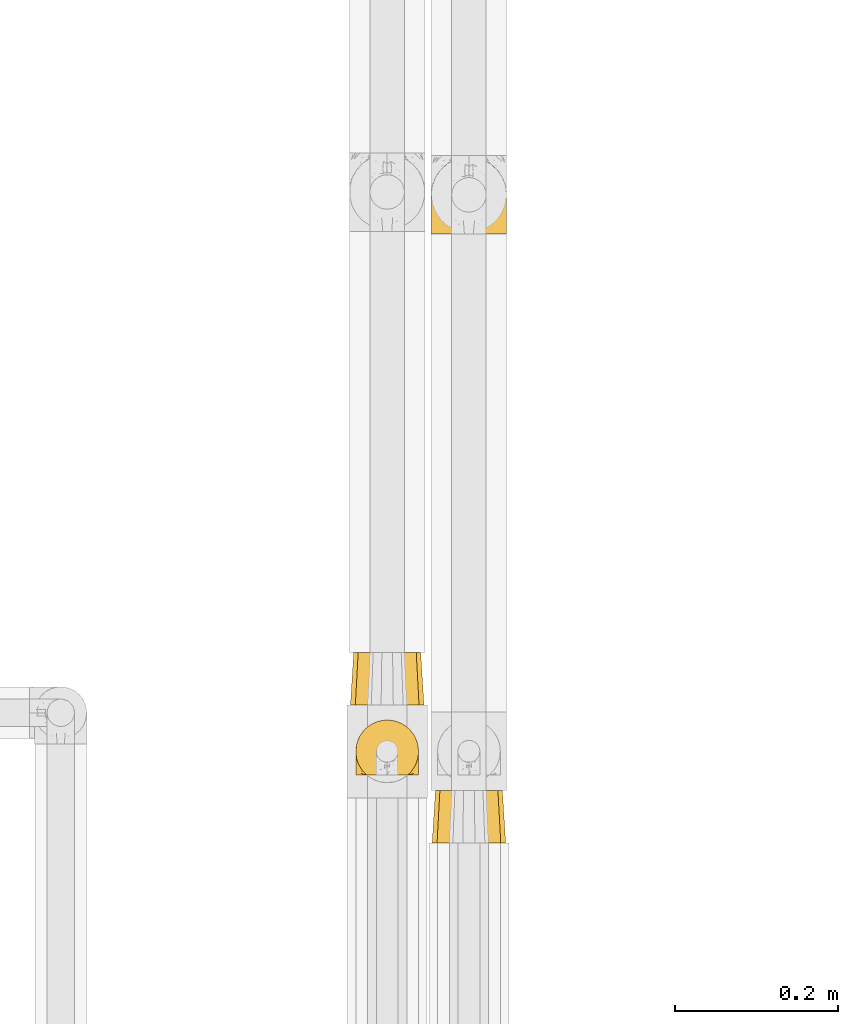
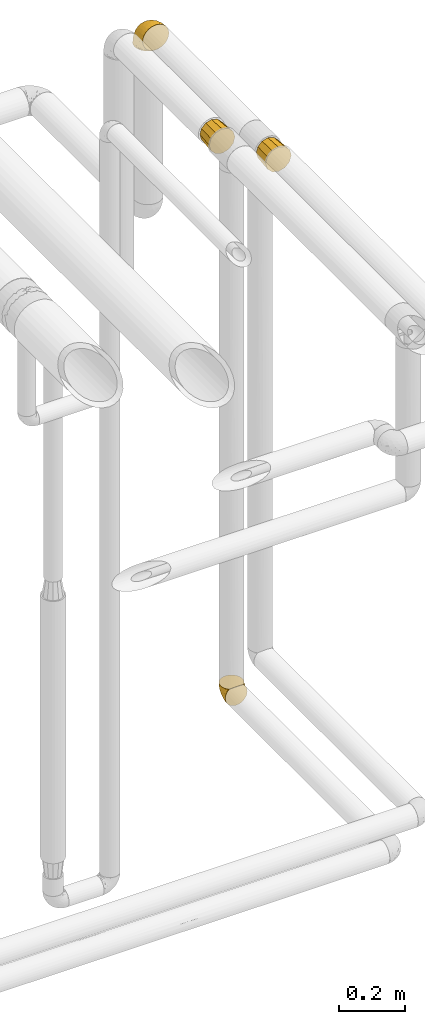
# One storey, part 509 of 827: 4 coverings.
"""IFC2X3 building model written with IfcOpenShell, lengths in millimetres."""

from ifc_helpers import new_model, entity, si_unit, converted_unit, derived_unit, direction, frame, origin, place, context, subcontext, project, spatial, faceted_brep, element, save


model = new_model("IFC2X3")

# Units and contexts
model_context = context("Model", 3, precision=0.01, world=origin(), true_north=direction((6.12303176911189e-17, 1.0)))
body_context = subcontext(model_context, "Body", "Model", "MODEL_VIEW")
ifc_project = project(units=[si_unit("LENGTHUNIT", "METRE", prefix="MILLI"), si_unit("AREAUNIT", "SQUARE_METRE"), si_unit("VOLUMEUNIT", "CUBIC_METRE"), converted_unit("PLANEANGLEUNIT", "DEGREE", entity("IfcRatioMeasure", 0.0174532925199433), si_unit("PLANEANGLEUNIT", "RADIAN"), dimensions=[0, 0, 0, 0, 0, 0, 0]), si_unit("MASSUNIT", "GRAM", prefix="KILO"), derived_unit("MASSDENSITYUNIT", [(si_unit("MASSUNIT", "GRAM", prefix="KILO"), 1), (si_unit("LENGTHUNIT", "METRE"), -3)]), derived_unit("MOMENTOFINERTIAUNIT", [(si_unit("LENGTHUNIT", "METRE"), 4)]), si_unit("TIMEUNIT", "SECOND"), si_unit("FREQUENCYUNIT", "HERTZ"), si_unit("THERMODYNAMICTEMPERATUREUNIT", "DEGREE_CELSIUS"), derived_unit("THERMALTRANSMITTANCEUNIT", [(si_unit("MASSUNIT", "GRAM", prefix="KILO"), 1), (si_unit("THERMODYNAMICTEMPERATUREUNIT", "KELVIN"), -1), (si_unit("TIMEUNIT", "SECOND"), -3)]), derived_unit("VOLUMETRICFLOWRATEUNIT", [(si_unit("LENGTHUNIT", "METRE"), 3), (si_unit("TIMEUNIT", "SECOND"), -1)]), derived_unit("MASSFLOWRATEUNIT", [(si_unit("MASSUNIT", "GRAM", prefix="KILO"), 1), (si_unit("TIMEUNIT", "SECOND"), -1)]), derived_unit("ROTATIONALFREQUENCYUNIT", [(si_unit("TIMEUNIT", "SECOND"), -1)]), si_unit("ELECTRICCURRENTUNIT", "AMPERE"), si_unit("ELECTRICVOLTAGEUNIT", "VOLT"), si_unit("POWERUNIT", "WATT"), si_unit("FORCEUNIT", "NEWTON", prefix="KILO"), si_unit("ILLUMINANCEUNIT", "LUX"), si_unit("LUMINOUSFLUXUNIT", "LUMEN"), si_unit("LUMINOUSINTENSITYUNIT", "CANDELA"), derived_unit("USERDEFINED", [(si_unit("MASSUNIT", "GRAM", prefix="KILO"), -1), (si_unit("LENGTHUNIT", "METRE"), -2), (si_unit("TIMEUNIT", "SECOND"), 3), (si_unit("LUMINOUSFLUXUNIT", "LUMEN"), 1)]), derived_unit("LINEARVELOCITYUNIT", [(si_unit("LENGTHUNIT", "METRE"), 1), (si_unit("TIMEUNIT", "SECOND"), -1)]), si_unit("PRESSUREUNIT", "PASCAL"), derived_unit("USERDEFINED", [(si_unit("LENGTHUNIT", "METRE"), -2), (si_unit("MASSUNIT", "GRAM", prefix="KILO"), 1), (si_unit("TIMEUNIT", "SECOND"), -2)]), derived_unit("LINEARFORCEUNIT", [(si_unit("MASSUNIT", "GRAM", prefix="KILO"), 1), (si_unit("LENGTHUNIT", "METRE"), 1), (si_unit("TIMEUNIT", "SECOND"), -2), (si_unit("LENGTHUNIT", "METRE"), -1)]), derived_unit("PLANARFORCEUNIT", [(si_unit("MASSUNIT", "GRAM", prefix="KILO"), 1), (si_unit("LENGTHUNIT", "METRE"), 1), (si_unit("TIMEUNIT", "SECOND"), -2), (si_unit("LENGTHUNIT", "METRE"), -2)])], contexts=[model_context])

# Site, building, storey
site_placement = place(None, origin())
site = spatial("IfcSite", under=ifc_project, at=site_placement, CompositionType="ELEMENT")
building_placement = place(site_placement, origin())
building = spatial("IfcBuilding", under=site, at=building_placement, CompositionType="ELEMENT")
storey_placement = place(building_placement, frame((0.0, 0.0, 28200.0)))
storey = spatial("IfcBuildingStorey", under=building, at=storey_placement, Name="08", CompositionType="ELEMENT", Elevation=28200.0)

# Coverings
covering_1_placement = place(storey_placement, frame((61012.59, 17422.14, 959.96)))
element("IfcCovering", 1, at=covering_1_placement, inside=storey, Name=":ADSK_", ObjectType=":ADSK_", PredefinedType="INSULATION", context=body_context, shape_type="Brep", body=[
    faceted_brep([(5.41, 1.6, 23.36), (9.99, 1.6, 16.07), (16.08, 1.6, 9.98), (23.37, 1.6, 5.4), (31.49, 1.6, 2.56), (40.05, 1.6, 1.6), (48.61, 1.6, 2.56), (56.73, 1.6, 5.41), (64.02, 1.6, 9.99), (70.11, 1.6, 16.08), (74.69, 1.6, 23.37), (77.53, 1.6, 31.49), (78.5, 1.6, 40.05), (77.63, 1.6, 48.15), (75.08, 1.6, 55.88), (70.97, 1.6, 62.9), (65.47, 1.6, 68.89), (63.27, 1.6, 68.89), (61.53, 1.6, 68.89), (59.57, 1.6, 68.89), (57.6, 1.6, 68.89), (55.63, 1.6, 68.89), (53.67, 1.6, 68.89), (51.7, 1.6, 68.89), (49.73, 1.6, 68.89), (47.54, 1.6, 68.89), (45.34, 1.6, 68.89), (43.15, 1.6, 68.89), (40.96, 1.6, 68.89), (38.76, 1.6, 68.89), (36.57, 1.6, 68.89), (34.37, 1.6, 68.89), (32.18, 1.6, 68.89), (29.98, 1.6, 68.89), (27.79, 1.6, 68.89), (25.6, 1.6, 68.89), (23.4, 1.6, 68.89), (21.21, 1.6, 68.89), (19.01, 1.6, 68.89), (16.82, 1.6, 68.89), (14.62, 1.6, 68.89), (9.12, 1.6, 62.89), (5.0, 1.6, 55.86), (2.46, 1.6, 48.13), (1.6, 1.6, 40.05), (2.56, 1.6, 31.49), (65.47, 1.85, 69.15), (70.97, 7.85, 69.15), (75.09, 14.87, 69.15), (77.63, 22.6, 69.15), (78.5, 30.7, 69.15), (77.19, 40.65, 69.15), (73.34, 49.92, 69.15), (67.23, 57.88, 69.15), (59.27, 63.99, 69.15), (50.0, 67.84, 69.15), (40.05, 69.15, 69.15), (30.09, 67.84, 69.15), (20.82, 63.99, 69.15), (12.86, 57.88, 69.15), (6.75, 49.92, 69.15), (2.91, 40.65, 69.15), (1.6, 30.7, 69.15), (2.46, 22.6, 69.15), (5.0, 14.87, 69.15), (9.12, 7.85, 69.15), (14.62, 1.85, 69.15), (16.82, 1.85, 69.15), (17.8, 1.85, 69.15), (19.39, 1.85, 69.15), (20.98, 1.85, 69.15), (22.57, 1.85, 69.15), (24.16, 1.85, 69.15), (25.75, 1.85, 69.15), (27.33, 1.85, 69.15), (28.92, 1.85, 69.15), (30.51, 1.85, 69.15), (32.1, 1.85, 69.15), (33.69, 1.85, 69.15), (35.28, 1.85, 69.15), (36.87, 1.85, 69.15), (38.46, 1.85, 69.15), (40.05, 1.85, 69.15), (41.63, 1.85, 69.15), (43.22, 1.85, 69.15), (44.81, 1.85, 69.15), (46.4, 1.85, 69.15), (47.99, 1.85, 69.15), (49.58, 1.85, 69.15), (51.17, 1.85, 69.15), (52.76, 1.85, 69.15), (54.72, 1.85, 69.15), (56.69, 1.85, 69.15), (58.88, 1.85, 69.15), (61.08, 1.85, 69.15), (63.27, 1.85, 69.15), (37.77, 1.77, 68.96), (36.07, 1.78, 68.97), (32.96, 1.77, 68.97), (31.36, 1.77, 68.97), (56.52, 1.76, 68.95), (54.96, 1.77, 68.96), (18.75, 1.79, 68.98), (58.07, 1.78, 68.97), (50.37, 1.78, 68.97), (23.36, 1.78, 68.98), (24.95, 1.78, 68.97), (42.43, 1.78, 68.97), (15.97, 1.74, 68.94), (51.96, 1.78, 68.98), (53.47, 1.78, 68.98), (48.63, 1.77, 68.96), (63.93, 1.78, 68.97), (40.93, 1.78, 68.98), (29.72, 1.78, 68.98), (62.4, 1.77, 68.97), (60.92, 1.77, 68.96), (17.31, 1.77, 68.97), (21.74, 1.78, 68.97), (34.56, 1.78, 68.98), (20.18, 1.77, 68.96), (14.62, 1.77, 68.97), (14.62, 1.72, 68.94), (14.62, 1.66, 68.92), (65.47, 1.77, 68.97), (65.47, 1.8, 69.02), (65.47, 1.82, 69.08), (59.5, 1.79, 68.98), (47.1, 1.78, 68.97), (45.61, 1.79, 68.98), (28.18, 1.78, 68.97), (14.62, 1.82, 69.08), (14.62, 1.8, 69.02), (26.61, 1.76, 68.96), (65.47, 1.66, 68.92), (65.47, 1.72, 68.94), (39.32, 1.78, 68.97), (44.12, 1.77, 68.96), (72.26, 9.41, 67.02), (76.57, 17.65, 63.33), (71.77, 7.41, 64.61), (78.5, 21.47, 49.27), (77.9, 15.21, 51.4), (78.5, 16.15, 43.94), (78.5, 28.75, 61.87), (75.52, 13.67, 61.54), (76.13, 12.79, 57.95), (77.81, 19.18, 56.12), (78.5, 29.16, 63.4), (72.4, 9.04, 65.41), (76.56, 7.41, 53.1), (71.77, 5.74, 63.04), (72.25, 3.72, 61.33), (78.5, 8.87, 41.99), (78.5, 26.8, 54.6), (75.75, 9.53, 56.6), (78.5, 7.34, 41.58), (50.46, 37.63, 13.72), (52.75, 17.92, 5.82), (40.05, 27.45, 6.74), (77.7, 37.01, 58.82), (77.66, 34.22, 51.58), (71.02, 45.87, 42.09), (63.45, 56.57, 46.12), (70.55, 52.31, 55.56), (75.57, 42.07, 52.38), (75.57, 44.74, 61.54), (72.61, 21.49, 23.76), (72.61, 11.02, 20.5), (67.24, 15.64, 14.64), (77.74, 26.02, 41.77), (57.43, 36.59, 16.28), (47.19, 65.49, 49.4), (54.76, 63.99, 52.34), (40.05, 15.2, 4.3), (63.45, 60.27, 58.67), (60.1, 45.25, 25.26), (63.72, 35.21, 20.17), (76.83, 22.52, 34.7), (76.34, 12.03, 28.67), (60.51, 13.32, 8.62), (72.59, 35.9, 33.37), (76.05, 33.87, 41.35), (66.15, 25.73, 17.15), (60.51, 26.34, 12.68), (51.88, 46.78, 21.47), (55.34, 59.54, 41.11), (48.67, 60.18, 37.53), (53.89, 53.93, 30.64), (46.73, 53.36, 26.66), (40.05, 49.36, 21.38), (40.05, 38.4, 14.06), (40.05, 66.44, 55.54), (63.95, 50.09, 35.17), (67.24, 41.08, 29.04), (69.62, 31.14, 24.34), (73.6, 28.19, 29.33), (40.05, 64.0, 43.3), (40.05, 56.68, 32.34), (4.52, 43.9, 57.75), (32.72, 65.46, 49.41), (27.18, 52.22, 27.85), (29.63, 37.61, 13.7), (12.86, 15.64, 14.63), (19.59, 13.31, 8.61), (9.54, 50.02, 48.85), (16.64, 59.28, 54.13), (17.48, 53.05, 37.84), (7.49, 21.48, 23.75), (7.49, 11.01, 20.49), (3.75, 12.03, 28.66), (20.75, 41.02, 20.83), (2.33, 35.39, 55.15), (1.6, 26.8, 54.6), (1.6, 28.75, 61.87), (1.6, 7.34, 41.58), (26.94, 65.81, 57.58), (9.54, 53.28, 59.91), (31.21, 59.8, 36.94), (25.33, 61.82, 45.72), (27.35, 17.91, 5.82), (8.17, 41.4, 37.91), (4.3, 40.48, 50.18), (19.59, 26.34, 12.67), (2.23, 31.68, 49.29), (2.45, 27.68, 42.64), (1.6, 16.15, 43.94), (1.6, 21.47, 49.27), (12.86, 28.05, 19.45), (3.27, 22.54, 34.7), (1.6, 8.87, 41.99), (2.29, 37.3, 62.29), (12.86, 41.07, 29.01), (6.89, 32.24, 31.47), (12.43, 47.4, 37.18), (4.1, 35.77, 43.45), (3.53, 17.65, 63.33), (6.88, 11.06, 67.23), (8.16, 8.55, 66.07), (9.02, 6.63, 65.22), (5.0, 12.77, 61.99), (3.96, 12.79, 57.95), (3.52, 7.41, 53.09), (2.4, 18.97, 56.84), (7.83, 3.72, 61.33), (8.32, 5.76, 63.06), (2.19, 15.21, 51.41), (4.34, 9.52, 56.61)], [[[0, 1, 2, 3, 4, 5, 6, 7, 8, 9, 10, 11, 12, 13, 14, 15, 16, 17, 18, 19, 20, 21, 22, 23, 24, 25, 26, 27, 28, 29, 30, 31, 32, 33, 34, 35, 36, 37, 38, 39, 40, 41, 42, 43, 44, 45]], [[46, 47, 48, 49, 50, 51, 52, 53, 54, 55, 56, 57, 58, 59, 60, 61, 62, 63, 64, 65, 66, 67, 68, 69, 70, 71, 72, 73, 74, 75, 76, 77, 78, 79, 80, 81, 82, 83, 84, 85, 86, 87, 88, 89, 90, 91, 92, 93, 94, 95]], [[96, 97, 30]], [[98, 77, 99]], [[100, 101, 21]], [[69, 68, 102]], [[20, 19, 103]], [[24, 23, 104]], [[20, 103, 100]], [[72, 105, 106]], [[84, 83, 107]], [[89, 88, 104]], [[108, 67, 66]], [[109, 110, 90]], [[111, 25, 24]], [[112, 17, 16]], [[82, 113, 83]], [[109, 23, 22]], [[114, 76, 75]], [[105, 36, 106]], [[104, 111, 24]], [[18, 115, 116]], [[97, 96, 80]], [[67, 108, 117]], [[105, 71, 118]], [[31, 97, 119]], [[102, 120, 69]], [[108, 121, 122, 123, 40]], [[112, 95, 115]], [[17, 115, 18]], [[94, 116, 115]], [[117, 68, 67]], [[38, 117, 39]], [[112, 124, 125, 126, 46]], [[17, 112, 115]], [[70, 120, 118]], [[39, 117, 108]], [[120, 38, 37]], [[120, 37, 118]], [[120, 70, 69]], [[116, 94, 127]], [[128, 86, 129]], [[117, 38, 102]], [[74, 130, 75]], [[99, 33, 32]], [[115, 95, 94]], [[39, 108, 40]], [[108, 66, 131, 132, 121]], [[105, 72, 71]], [[118, 37, 36]], [[71, 70, 118]], [[35, 106, 36]], [[36, 105, 118]], [[35, 133, 106]], [[74, 73, 133]], [[106, 133, 73]], [[99, 114, 33]], [[133, 35, 34]], [[73, 72, 106]], [[95, 112, 46]], [[112, 16, 134, 135, 124]], [[130, 114, 75]], [[99, 76, 114]], [[114, 130, 33]], [[34, 33, 130]], [[78, 77, 98]], [[98, 119, 78]], [[130, 133, 34]], [[133, 130, 74]], [[79, 97, 80]], [[98, 99, 32]], [[98, 32, 31]], [[77, 76, 99]], [[97, 79, 119]], [[136, 96, 29]], [[30, 97, 31]], [[136, 29, 28]], [[81, 80, 96]], [[29, 96, 30]], [[31, 119, 98]], [[119, 79, 78]], [[96, 136, 81]], [[82, 81, 136]], [[113, 107, 83]], [[84, 107, 137]], [[107, 27, 137]], [[113, 28, 107]], [[27, 107, 28]], [[85, 84, 137]], [[137, 27, 26]], [[113, 136, 28]], [[136, 113, 82]], [[109, 89, 104]], [[86, 85, 129]], [[89, 109, 90]], [[111, 87, 128]], [[26, 129, 137]], [[88, 111, 104]], [[25, 111, 128]], [[22, 110, 109]], [[23, 109, 104]], [[110, 91, 90]], [[100, 92, 101]], [[110, 22, 101]], [[91, 110, 101]], [[116, 19, 18]], [[111, 88, 87]], [[127, 103, 19]], [[25, 128, 26]], [[86, 128, 87]], [[128, 129, 26]], [[137, 129, 85]], [[120, 102, 38]], [[117, 102, 68]], [[91, 101, 92]], [[21, 101, 22]], [[93, 92, 103]], [[100, 21, 20]], [[100, 103, 92]], [[127, 93, 103]], [[93, 127, 94]], [[116, 127, 19]], [[126, 138, 47]], [[48, 138, 139]], [[140, 125, 124]], [[141, 142, 143]], [[144, 49, 139]], [[145, 140, 146]], [[48, 139, 49]], [[139, 145, 147]], [[49, 144, 148, 50]], [[126, 125, 149]], [[14, 13, 150]], [[151, 146, 140]], [[149, 140, 145]], [[152, 151, 135]], [[152, 14, 150]], [[16, 15, 134]], [[13, 153, 150]], [[124, 151, 140]], [[141, 147, 142]], [[14, 152, 15]], [[15, 152, 134]], [[47, 46, 126]], [[139, 154, 144]], [[138, 48, 47]], [[125, 140, 149]], [[135, 134, 152]], [[146, 155, 142]], [[145, 146, 147]], [[149, 139, 138]], [[147, 141, 154]], [[147, 146, 142]], [[139, 147, 154]], [[139, 149, 145]], [[149, 138, 126]], [[155, 146, 151]], [[150, 143, 142]], [[152, 155, 151]], [[150, 142, 155]], [[13, 12, 156, 153]], [[153, 143, 150]], [[152, 150, 155]], [[151, 124, 135]], [[157, 158, 159]], [[160, 154, 161]], [[162, 163, 164]], [[165, 166, 160]], [[167, 168, 169]], [[141, 170, 161]], [[156, 12, 11]], [[158, 157, 171]], [[172, 55, 173]], [[158, 6, 174]], [[175, 54, 53]], [[52, 166, 164]], [[52, 164, 53]], [[54, 175, 173]], [[166, 52, 51]], [[176, 177, 171]], [[178, 143, 179]], [[156, 11, 179]], [[8, 7, 180]], [[169, 9, 8]], [[179, 143, 153, 156]], [[179, 11, 10]], [[168, 179, 10]], [[181, 162, 182]], [[179, 167, 178]], [[183, 184, 177]], [[183, 169, 184]], [[176, 171, 185]], [[172, 186, 187]], [[158, 7, 6]], [[159, 158, 174]], [[184, 180, 158]], [[54, 173, 55]], [[180, 169, 8]], [[188, 189, 187]], [[9, 168, 10]], [[186, 188, 187]], [[190, 157, 159, 191]], [[55, 172, 192]], [[176, 193, 194]], [[161, 170, 182]], [[162, 164, 165]], [[175, 164, 163]], [[51, 50, 148]], [[167, 195, 196]], [[178, 182, 170]], [[6, 5, 174]], [[158, 180, 7]], [[169, 180, 184]], [[169, 168, 9]], [[179, 168, 167]], [[182, 162, 165]], [[162, 194, 193]], [[161, 165, 160]], [[195, 181, 196]], [[192, 172, 197]], [[192, 56, 55]], [[189, 190, 198]], [[198, 197, 187]], [[172, 187, 197]], [[185, 189, 188]], [[198, 187, 189]], [[186, 172, 173]], [[173, 163, 186]], [[193, 186, 163]], [[176, 185, 188]], [[185, 157, 190]], [[188, 186, 193]], [[177, 176, 194]], [[188, 193, 176]], [[162, 193, 163]], [[195, 177, 194]], [[171, 177, 184]], [[181, 195, 194]], [[183, 167, 169]], [[162, 181, 194]], [[196, 182, 178]], [[158, 171, 184]], [[171, 157, 185]], [[177, 195, 183]], [[167, 183, 195]], [[182, 196, 181]], [[178, 170, 143]], [[178, 167, 196]], [[164, 175, 53]], [[173, 175, 163]], [[160, 51, 148]], [[164, 166, 165]], [[51, 160, 166]], [[160, 148, 144, 154]], [[141, 161, 154]], [[182, 165, 161]], [[190, 189, 185]], [[143, 170, 141]], [[60, 199, 61]], [[197, 200, 192]], [[201, 190, 202]], [[200, 57, 192]], [[203, 204, 2]], [[205, 206, 207]], [[208, 209, 210]], [[211, 207, 201]], [[212, 213, 214]], [[45, 215, 210]], [[216, 206, 58]], [[45, 44, 215]], [[59, 217, 60]], [[60, 217, 199]], [[0, 45, 210]], [[218, 201, 219]], [[202, 159, 220]], [[205, 221, 222]], [[223, 204, 203]], [[1, 203, 2]], [[57, 200, 216]], [[220, 3, 204]], [[220, 174, 4]], [[1, 0, 209]], [[212, 224, 213]], [[225, 226, 227]], [[228, 223, 203]], [[208, 210, 229]], [[210, 226, 229]], [[3, 220, 4]], [[58, 206, 59]], [[209, 203, 1]], [[202, 220, 223]], [[228, 203, 208]], [[202, 211, 201]], [[3, 2, 204]], [[202, 190, 191, 159]], [[210, 215, 230, 226]], [[199, 212, 231]], [[232, 233, 221]], [[233, 208, 229]], [[207, 206, 219]], [[217, 206, 205]], [[227, 224, 225]], [[233, 232, 228]], [[201, 207, 219]], [[234, 232, 221]], [[218, 219, 200]], [[202, 223, 211]], [[174, 220, 159]], [[174, 5, 4]], [[61, 231, 62]], [[220, 204, 223]], [[210, 209, 0]], [[203, 209, 208]], [[225, 233, 229]], [[224, 227, 213]], [[221, 233, 235]], [[57, 56, 192]], [[198, 218, 197]], [[200, 219, 216]], [[201, 198, 190]], [[197, 218, 200]], [[198, 201, 218]], [[206, 216, 219]], [[58, 57, 216]], [[231, 212, 214]], [[222, 212, 199]], [[228, 211, 223]], [[207, 211, 232]], [[62, 231, 214]], [[199, 231, 61]], [[233, 228, 208]], [[211, 228, 232]], [[222, 221, 235]], [[234, 205, 207]], [[206, 217, 59]], [[199, 217, 205]], [[205, 222, 199]], [[224, 222, 235]], [[222, 224, 212]], [[224, 235, 225]], [[233, 225, 235]], [[226, 225, 229]], [[205, 234, 221]], [[207, 232, 234]], [[63, 214, 236]], [[214, 213, 236]], [[214, 63, 62]], [[237, 236, 238]], [[238, 132, 131]], [[236, 237, 64]], [[239, 240, 241]], [[63, 236, 64]], [[131, 66, 65]], [[237, 131, 65]], [[242, 230, 43]], [[237, 65, 64]], [[239, 121, 132]], [[42, 242, 43]], [[241, 240, 243]], [[41, 123, 244]], [[43, 230, 215, 44]], [[244, 122, 245]], [[227, 246, 243]], [[241, 243, 246]], [[121, 239, 245]], [[41, 40, 123]], [[132, 238, 239]], [[244, 42, 41]], [[131, 237, 238]], [[240, 239, 238]], [[245, 239, 241]], [[247, 241, 246]], [[247, 244, 245]], [[238, 236, 240]], [[243, 236, 213]], [[236, 243, 240]], [[226, 246, 227]], [[243, 213, 227]], [[226, 242, 246]], [[241, 247, 245]], [[246, 242, 247]], [[244, 247, 242]], [[242, 226, 230]], [[42, 244, 242]], [[122, 244, 123]], [[122, 121, 245]]]),
])
covering_2_placement = place(storey_placement, frame((61006.04, 17509.83, 2953.15)))
element("IfcCovering", 2, at=covering_2_placement, inside=storey, Name=":ADSK_", ObjectType=":ADSK_", PredefinedType="INSULATION", context=body_context, shape_type="Brep", body=[
    faceted_brep([(67.1, 64.0, 82.1), (74.6, 64.0, 74.6), (82.1, 64.0, 67.1), (84.85, 64.0, 56.85), (87.6, 64.0, 46.6), (84.85, 64.0, 36.35), (82.1, 64.0, 26.1), (74.6, 64.0, 18.59), (67.1, 64.0, 11.09), (56.85, 64.0, 8.34), (46.6, 64.0, 5.6), (36.35, 64.0, 8.34), (26.1, 64.0, 11.09), (18.59, 64.0, 18.59), (11.09, 64.0, 26.1), (8.34, 64.0, 36.35), (5.6, 64.0, 46.6), (8.34, 64.0, 56.85), (11.09, 64.0, 67.1), (18.59, 64.0, 74.6), (26.1, 64.0, 82.1), (36.35, 64.0, 84.85), (46.6, 64.0, 87.6), (56.85, 64.0, 84.85), (1.6, 0.0, 46.6), (5.18, 0.0, 33.21), (7.62, 0.0, 24.1), (15.86, 0.0, 15.86), (24.1, 0.0, 7.62), (33.21, 0.0, 5.18), (46.6, 0.0, 1.6), (59.99, 0.0, 5.18), (69.1, 0.0, 7.62), (77.33, 0.0, 15.86), (85.57, 0.0, 24.1), (88.01, 0.0, 33.21), (91.6, 0.0, 46.6), (88.01, 0.0, 59.99), (85.57, 0.0, 69.1), (77.33, 0.0, 77.33), (69.1, 0.0, 85.57), (59.99, 0.0, 88.01), (46.6, 0.0, 91.6), (33.21, 0.0, 88.01), (24.1, 0.0, 85.57), (15.86, 0.0, 77.33), (7.62, 0.0, 69.1), (5.18, 0.0, 59.99)], [[[0, 1, 2, 3, 4, 5, 6, 7, 8, 9, 10, 11, 12, 13, 14, 15, 16, 17, 18, 19, 20, 21, 22, 23]], [[24, 25, 26, 27, 28, 29, 30, 31, 32, 33, 34, 35, 36, 37, 38, 39, 40, 41, 42, 43, 44, 45, 46, 47]], [[20, 44, 43, 42, 22, 21]], [[46, 45, 44, 20, 19, 18]], [[17, 16, 24, 47, 46, 18]], [[2, 38, 37, 36, 4, 3]], [[40, 39, 38, 2, 1, 0]], [[23, 22, 42, 41, 40, 0]], [[8, 32, 31, 30, 10, 9]], [[34, 33, 32, 8, 7, 6]], [[5, 4, 36, 35, 34, 6]], [[14, 26, 25, 24, 16, 15]], [[28, 27, 26, 14, 13, 12]], [[11, 10, 30, 29, 28, 12]]]),
])
covering_3_placement = place(storey_placement, frame((61106.04, 17340.83, 2953.15)))
element("IfcCovering", 3, at=covering_3_placement, inside=storey, Name=":ADSK_", ObjectType=":ADSK_", PredefinedType="INSULATION", context=body_context, shape_type="Brep", body=[
    faceted_brep([(69.1, 0.0, 85.57), (59.99, 0.0, 88.01), (46.6, 0.0, 91.6), (33.21, 0.0, 88.01), (24.1, 0.0, 85.57), (15.86, 0.0, 77.33), (7.62, 0.0, 69.1), (5.18, 0.0, 59.99), (1.6, 0.0, 46.6), (5.18, 0.0, 33.21), (7.62, 0.0, 24.1), (15.86, 0.0, 15.86), (24.1, 0.0, 7.62), (33.21, 0.0, 5.18), (46.6, 0.0, 1.6), (59.99, 0.0, 5.18), (69.1, 0.0, 7.62), (77.33, 0.0, 15.86), (85.57, 0.0, 24.1), (88.01, 0.0, 33.21), (91.6, 0.0, 46.6), (88.01, 0.0, 59.99), (85.57, 0.0, 69.1), (77.33, 0.0, 77.33), (87.6, 64.0, 46.6), (84.85, 64.0, 36.35), (82.1, 64.0, 26.1), (74.6, 64.0, 18.59), (67.1, 64.0, 11.09), (56.85, 64.0, 8.34), (46.6, 64.0, 5.6), (36.35, 64.0, 8.34), (26.1, 64.0, 11.09), (18.59, 64.0, 18.59), (11.09, 64.0, 26.1), (8.34, 64.0, 36.35), (5.6, 64.0, 46.6), (8.34, 64.0, 56.85), (11.09, 64.0, 67.1), (18.59, 64.0, 74.6), (26.1, 64.0, 82.1), (36.35, 64.0, 84.85), (46.6, 64.0, 87.6), (56.85, 64.0, 84.85), (67.1, 64.0, 82.1), (74.6, 64.0, 74.6), (82.1, 64.0, 67.1), (84.85, 64.0, 56.85)], [[[0, 1, 2, 3, 4, 5, 6, 7, 8, 9, 10, 11, 12, 13, 14, 15, 16, 17, 18, 19, 20, 21, 22, 23]], [[24, 25, 26, 27, 28, 29, 30, 31, 32, 33, 34, 35, 36, 37, 38, 39, 40, 41, 42, 43, 44, 45, 46, 47]], [[34, 10, 9, 8, 36, 35]], [[11, 10, 34, 33, 32, 12]], [[31, 30, 14, 13, 12, 32]], [[28, 16, 15, 14, 30, 29]], [[17, 16, 28, 27, 26, 18]], [[25, 24, 20, 19, 18, 26]], [[46, 22, 21, 20, 24, 47]], [[23, 22, 46, 45, 44, 0]], [[43, 42, 2, 1, 0, 44]], [[40, 4, 3, 2, 42, 41]], [[5, 4, 40, 39, 38, 6]], [[37, 36, 8, 7, 6, 38]]]),
])
covering_4_placement = place(storey_placement, frame((61104.84, 18084.24, 2950.15)))
element("IfcCovering", 4, at=covering_4_placement, inside=storey, Name=":ADSK_", ObjectType=":ADSK_", PredefinedType="INSULATION", context=body_context, shape_type="Brep", body=[
    faceted_brep([(11.68, 78.41, 1.6), (19.0, 85.72, 1.6), (27.76, 91.22, 1.6), (37.52, 94.64, 1.6), (47.8, 95.8, 1.6), (58.08, 94.64, 1.6), (67.85, 91.22, 1.6), (76.61, 85.71, 1.6), (83.92, 78.39, 1.6), (89.42, 69.63, 1.6), (92.84, 59.87, 1.6), (94.0, 49.6, 1.6), (93.53, 45.45, 1.6), (93.18, 42.38, 1.6), (92.84, 39.31, 1.6), (91.13, 34.43, 1.6), (89.42, 29.54, 1.6), (86.66, 25.16, 1.6), (83.91, 20.78, 1.6), (80.25, 17.13, 1.6), (76.59, 13.47, 1.6), (67.83, 7.97, 1.6), (62.95, 6.26, 1.6), (58.07, 4.55, 1.6), (47.8, 3.4, 1.6), (37.51, 4.55, 1.6), (32.63, 6.26, 1.6), (27.74, 7.97, 1.6), (18.98, 13.48, 1.6), (15.33, 17.14, 1.6), (11.67, 20.8, 1.6), (8.92, 25.18, 1.6), (6.17, 29.56, 1.6), (4.46, 34.44, 1.6), (2.75, 39.32, 1.6), (2.41, 42.39, 1.6), (2.06, 45.45, 1.6), (1.6, 49.6, 1.6), (2.75, 59.88, 1.6), (6.17, 69.65, 1.6), (47.8, 1.6, 3.4), (59.75, 1.6, 4.97), (70.9, 1.6, 9.58), (75.68, 1.6, 13.26), (80.46, 1.6, 16.93), (84.13, 1.6, 21.71), (87.81, 1.6, 26.5), (90.11, 1.6, 32.07), (92.42, 1.6, 37.64), (92.9, 1.6, 41.25), (93.17, 1.6, 43.34), (93.45, 1.6, 45.42), (94.0, 1.6, 49.6), (92.42, 1.6, 61.55), (87.81, 1.6, 72.7), (80.46, 1.6, 82.26), (70.9, 1.6, 89.61), (59.75, 1.6, 94.22), (47.8, 1.6, 95.8), (35.84, 1.6, 94.22), (24.7, 1.6, 89.61), (15.13, 1.6, 82.26), (7.78, 1.6, 72.7), (3.17, 1.6, 61.55), (1.6, 1.6, 49.6), (2.14, 1.6, 45.42), (2.69, 1.6, 41.25), (3.17, 1.6, 37.64), (5.48, 1.6, 32.07), (7.78, 1.6, 26.5), (11.46, 1.6, 21.71), (15.13, 1.6, 16.93), (19.91, 1.6, 13.26), (24.7, 1.6, 9.58), (35.84, 1.6, 4.97), (23.61, 36.81, 81.55), (31.99, 23.28, 90.4), (35.87, 45.8, 83.0), (47.8, 30.7, 91.18), (40.43, 21.2, 93.13), (47.8, 12.96, 94.0), (31.83, 66.19, 66.19), (23.37, 54.51, 70.92), (21.41, 17.98, 85.95), (3.07, 36.69, 49.74), (1.6, 35.54, 35.54), (1.6, 31.64, 38.14), (1.6, 27.75, 40.74), (1.6, 23.86, 43.34), (1.6, 19.96, 45.94), (13.45, 22.8, 77.59), (15.25, 42.67, 71.17), (8.07, 33.21, 65.81), (16.0, 59.45, 59.03), (17.34, 71.5, 45.85), (10.58, 62.66, 45.79), (5.34, 54.5, 41.42), (2.39, 47.57, 34.51), (8.36, 48.81, 56.04), (10.04, 74.98, 15.15), (2.59, 18.7, 56.51), (6.28, 15.75, 68.39), (34.28, 91.17, 23.33), (38.73, 85.28, 42.86), (27.25, 82.58, 39.42), (29.88, 75.78, 53.58), (38.6, 74.98, 59.17), (23.44, 67.27, 59.06), (25.25, 87.38, 22.63), (17.23, 82.04, 20.55), (47.8, 94.0, 12.96), (47.8, 77.8, 56.96), (47.8, 67.38, 67.38), (2.53, 56.2, 18.72), (1.6, 48.85, 5.33), (1.6, 48.11, 9.07), (1.6, 47.57, 11.79), (1.6, 47.03, 14.51), (1.6, 46.48, 17.24), (1.6, 45.94, 19.96), (5.71, 65.78, 21.03), (1.6, 17.24, 46.48), (1.6, 14.51, 47.03), (1.6, 11.79, 47.57), (1.6, 9.07, 48.11), (1.6, 7.2, 48.48), (1.6, 5.33, 48.85), (47.8, 91.18, 30.7), (1.6, 43.34, 23.86), (1.6, 40.74, 27.75), (1.6, 38.14, 31.64), (11.89, 72.73, 31.26), (47.8, 56.96, 77.8), (39.69, 62.23, 72.75), (47.8, 84.49, 43.83), (47.8, 43.83, 84.49), (13.84, 12.05, 14.58), (9.16, 18.95, 16.17), (15.79, 13.02, 10.82), (25.75, 8.34, 4.64), (16.09, 14.63, 7.71), (7.51, 11.09, 25.13), (3.99, 13.66, 32.66), (2.66, 20.08, 34.94), (3.16, 9.61, 36.76), (2.35, 9.48, 40.48), (2.23, 16.1, 39.25), (38.35, 3.42, 3.69), (6.18, 26.63, 13.99), (2.7, 33.72, 21.85), (2.93, 34.77, 17.93), (16.01, 6.75, 15.11), (9.08, 13.31, 21.14), (9.3, 21.11, 12.7), (11.68, 19.94, 7.21), (4.65, 8.67, 32.27), (3.65, 26.11, 25.68), (3.61, 29.3, 22.18), (12.8, 6.32, 18.79), (2.43, 39.92, 10.12), (6.83, 27.05, 9.47), (21.65, 6.04, 10.45), (3.7, 34.4, 11.29), (47.8, 2.87, 2.87), (3.37, 20.92, 31.16), (7.03, 27.43, 6.31), (7.87, 7.54, 25.62), (7.26, 18.45, 21.18), (3.41, 23.88, 28.81), (23.81, 7.77, 7.45), (86.5, 13.3, 21.14), (88.08, 11.09, 25.13), (82.79, 6.33, 18.79), (94.0, 9.07, 48.11), (94.0, 5.33, 48.85), (94.0, 14.51, 47.03), (94.0, 11.79, 47.57), (57.24, 3.42, 3.69), (71.76, 7.76, 7.44), (94.0, 47.03, 14.51), (94.0, 47.57, 11.79), (94.0, 48.85, 5.33), (94.0, 48.11, 9.07), (79.49, 14.62, 7.71), (88.75, 27.03, 9.47), (92.93, 20.08, 34.94), (92.22, 20.92, 31.16), (94.0, 27.75, 40.74), (94.0, 31.64, 38.14), (92.43, 9.61, 36.76), (93.24, 9.48, 40.48), (69.82, 8.33, 4.63), (79.57, 6.74, 15.11), (81.74, 12.04, 14.58), (94.0, 23.86, 43.34), (94.0, 19.96, 45.94), (93.36, 16.1, 39.25), (83.9, 19.93, 7.21), (86.28, 21.1, 12.69), (93.16, 39.92, 10.14), (92.88, 33.68, 21.81), (91.98, 29.28, 22.19), (89.41, 26.62, 14.0), (91.93, 26.08, 25.69), (86.42, 18.93, 16.17), (88.82, 27.87, 6.66), (92.66, 34.75, 17.92), (73.93, 6.04, 10.45), (94.0, 38.14, 31.64), (79.5, 12.79, 10.64), (91.89, 34.41, 11.31), (94.0, 45.94, 19.96), (94.0, 43.34, 23.86), (94.0, 40.74, 27.75), (91.6, 13.66, 32.66), (94.0, 17.24, 46.48), (90.94, 8.67, 32.27), (94.0, 35.54, 35.54), (92.16, 23.83, 28.77), (88.32, 18.43, 21.17), (86.13, 6.03, 23.36), (94.0, 46.48, 17.24), (93.2, 34.52, 47.58), (55.16, 21.2, 93.13), (82.02, 23.82, 77.44), (84.29, 41.32, 66.78), (76.94, 47.62, 71.68), (68.33, 52.66, 74.96), (71.98, 36.81, 81.55), (92.52, 49.75, 36.7), (92.9, 19.07, 56.9), (59.72, 45.8, 83.0), (63.6, 23.28, 90.4), (88.89, 21.35, 67.83), (74.18, 17.98, 85.95), (68.35, 82.57, 39.41), (61.33, 91.17, 23.33), (56.86, 85.27, 42.87), (68.62, 73.89, 53.92), (63.76, 66.19, 66.19), (72.19, 62.43, 64.12), (88.69, 63.53, 33.13), (92.19, 58.45, 23.1), (89.75, 67.16, 16.98), (59.86, 76.72, 55.72), (55.9, 62.22, 72.75), (77.99, 81.54, 23.77), (85.21, 74.8, 18.41), (74.99, 75.83, 43.7), (90.23, 41.45, 54.53), (70.75, 88.2, 17.73), (81.72, 71.6, 38.98), (86.53, 56.23, 50.28), (79.6, 59.44, 59.02)], [[[0, 1, 2, 3, 4, 5, 6, 7, 8, 9, 10, 11, 12, 13, 14, 15, 16, 17, 18, 19, 20, 21, 22, 23, 24, 25, 26, 27, 28, 29, 30, 31, 32, 33, 34, 35, 36, 37, 38, 39]], [[40, 41, 42, 43, 44, 45, 46, 47, 48, 49, 50, 51, 52, 53, 54, 55, 56, 57, 58, 59, 60, 61, 62, 63, 64, 65, 66, 67, 68, 69, 70, 71, 72, 73, 74]], [[75, 76, 77]], [[78, 79, 80]], [[77, 81, 82]], [[76, 75, 83]], [[84, 85, 86, 87, 88, 89]], [[90, 91, 92]], [[76, 60, 59]], [[93, 94, 95]], [[90, 62, 61]], [[83, 61, 60]], [[96, 97, 84]], [[98, 93, 95]], [[0, 39, 99]], [[100, 84, 89]], [[62, 101, 63]], [[2, 102, 3]], [[92, 84, 100]], [[103, 102, 104]], [[103, 105, 106]], [[93, 107, 94]], [[1, 108, 2]], [[92, 101, 90]], [[108, 1, 109]], [[102, 110, 3]], [[93, 82, 107]], [[102, 108, 104]], [[111, 106, 112]], [[109, 0, 99]], [[113, 37, 114, 115, 116, 117, 118, 119]], [[120, 38, 113]], [[100, 89, 121, 122, 123, 124, 125, 126, 64]], [[127, 102, 103]], [[97, 119, 128, 129, 130, 85]], [[99, 120, 131]], [[132, 133, 77]], [[59, 80, 79]], [[1, 0, 109]], [[98, 84, 92]], [[94, 109, 131]], [[120, 39, 38]], [[93, 91, 82]], [[104, 94, 105]], [[97, 113, 119]], [[95, 120, 96]], [[83, 90, 61]], [[91, 93, 98]], [[64, 63, 100]], [[100, 63, 101]], [[77, 76, 79]], [[133, 106, 81]], [[84, 97, 85]], [[113, 96, 120]], [[113, 97, 96]], [[37, 113, 38]], [[110, 102, 127]], [[110, 4, 3]], [[103, 111, 134, 127]], [[90, 75, 91]], [[82, 81, 107]], [[91, 75, 82]], [[77, 82, 75]], [[76, 83, 60]], [[90, 83, 75]], [[105, 107, 81]], [[94, 131, 95]], [[105, 94, 107]], [[109, 94, 104]], [[120, 95, 131]], [[98, 95, 96]], [[84, 98, 96]], [[98, 92, 91]], [[106, 105, 81]], [[103, 104, 105]], [[112, 106, 133]], [[103, 106, 111]], [[112, 133, 132]], [[81, 77, 133]], [[77, 78, 135, 132]], [[120, 99, 39]], [[109, 99, 131]], [[59, 58, 80]], [[59, 79, 76]], [[90, 101, 62]], [[100, 101, 92]], [[2, 108, 102]], [[109, 104, 108]], [[78, 77, 79]], [[136, 137, 138]], [[27, 139, 140]], [[141, 142, 143]], [[144, 145, 121]], [[146, 89, 88]], [[147, 139, 25]], [[148, 149, 150]], [[136, 151, 152]], [[147, 40, 74]], [[24, 147, 25]], [[140, 153, 154]], [[33, 116, 34]], [[73, 72, 151]], [[114, 37, 36, 35, 34, 116, 115]], [[146, 155, 144]], [[156, 85, 130]], [[157, 149, 148]], [[151, 158, 152]], [[117, 33, 159]], [[29, 154, 160]], [[161, 74, 73]], [[162, 128, 119]], [[66, 65, 64, 126, 125, 124, 123, 122, 67]], [[163, 147, 24]], [[27, 140, 28]], [[149, 129, 150]], [[139, 27, 26, 25]], [[68, 144, 69]], [[129, 128, 150]], [[164, 87, 86]], [[130, 129, 149]], [[122, 145, 67]], [[154, 153, 148]], [[162, 119, 159]], [[165, 30, 160]], [[150, 160, 148]], [[128, 162, 150]], [[30, 165, 31]], [[145, 144, 68]], [[89, 146, 144]], [[87, 164, 143]], [[166, 155, 142]], [[88, 87, 143]], [[162, 160, 150]], [[160, 30, 29]], [[154, 29, 28]], [[140, 154, 28]], [[160, 154, 148]], [[140, 137, 153]], [[157, 148, 153]], [[156, 130, 157]], [[153, 137, 157]], [[157, 137, 156]], [[167, 137, 136]], [[168, 85, 156]], [[152, 168, 167]], [[167, 168, 156]], [[164, 152, 141]], [[71, 158, 72]], [[152, 167, 136]], [[88, 142, 146]], [[144, 155, 69]], [[146, 142, 155]], [[70, 166, 71]], [[142, 141, 166]], [[70, 69, 155]], [[141, 158, 71]], [[161, 73, 151]], [[138, 137, 140]], [[161, 136, 169]], [[136, 161, 151]], [[74, 161, 169]], [[152, 158, 141]], [[151, 72, 158]], [[168, 152, 164]], [[137, 167, 156]], [[164, 86, 168]], [[85, 168, 86]], [[116, 33, 117]], [[130, 149, 157]], [[67, 145, 68]], [[121, 89, 144]], [[145, 122, 121]], [[40, 147, 163]], [[169, 147, 74]], [[159, 33, 32]], [[162, 159, 32]], [[159, 119, 118, 117]], [[139, 147, 169]], [[139, 169, 138]], [[162, 32, 31]], [[141, 143, 164]], [[88, 143, 142]], [[71, 166, 141]], [[155, 166, 70]], [[139, 138, 140]], [[169, 136, 138]], [[160, 162, 165]], [[162, 31, 165]], [[170, 171, 172]], [[173, 174, 52, 51, 50, 49, 48, 175, 176]], [[177, 178, 41]], [[179, 15, 180]], [[12, 11, 181, 182, 180, 14, 13]], [[183, 21, 20]], [[19, 18, 184]], [[185, 186, 187]], [[186, 188, 187]], [[43, 172, 44]], [[189, 190, 47]], [[23, 22, 21, 191]], [[170, 192, 193]], [[40, 163, 177]], [[194, 195, 196]], [[24, 23, 177]], [[197, 198, 183]], [[199, 15, 179]], [[47, 46, 189]], [[200, 201, 202]], [[201, 203, 204]], [[205, 206, 184]], [[207, 41, 178]], [[16, 15, 199]], [[14, 180, 15]], [[202, 201, 198]], [[208, 201, 200]], [[163, 24, 177]], [[48, 47, 190]], [[196, 195, 189]], [[197, 184, 202]], [[204, 193, 209]], [[210, 211, 212]], [[206, 212, 213]], [[205, 17, 210]], [[184, 206, 202]], [[210, 212, 206]], [[185, 194, 214]], [[189, 215, 190]], [[216, 45, 214]], [[186, 171, 170]], [[189, 216, 196]], [[197, 20, 19]], [[194, 185, 187]], [[197, 183, 20]], [[184, 197, 19]], [[197, 202, 198]], [[206, 200, 202]], [[204, 183, 198]], [[201, 208, 203]], [[203, 208, 217]], [[204, 198, 201]], [[217, 188, 218]], [[193, 219, 170]], [[171, 186, 185]], [[170, 218, 186]], [[170, 219, 218]], [[42, 207, 192]], [[171, 220, 172]], [[216, 189, 46]], [[214, 194, 196]], [[44, 220, 45]], [[214, 196, 216]], [[216, 46, 45]], [[214, 45, 220]], [[192, 43, 42]], [[204, 203, 219]], [[207, 193, 192]], [[209, 193, 178]], [[41, 207, 42]], [[193, 207, 178]], [[43, 192, 172]], [[170, 172, 192]], [[204, 219, 193]], [[219, 203, 218]], [[217, 218, 203]], [[188, 186, 218]], [[206, 213, 200]], [[208, 200, 213]], [[199, 210, 16]], [[215, 189, 195]], [[215, 175, 190]], [[175, 48, 190]], [[199, 179, 221, 211]], [[210, 199, 211]], [[23, 191, 177]], [[40, 177, 41]], [[178, 177, 191]], [[21, 183, 191]], [[209, 191, 183]], [[205, 18, 17]], [[17, 16, 210]], [[171, 185, 214]], [[172, 220, 44]], [[214, 220, 171]], [[191, 209, 178]], [[204, 209, 183]], [[206, 205, 210]], [[18, 205, 184]], [[222, 195, 194, 187, 188, 217]], [[57, 223, 80]], [[224, 225, 226]], [[226, 227, 228]], [[229, 217, 208, 213, 212, 211]], [[230, 52, 174, 173, 176, 175, 215, 195]], [[231, 232, 228]], [[231, 78, 223]], [[223, 57, 232]], [[224, 233, 225]], [[233, 54, 53]], [[234, 232, 56]], [[56, 55, 234]], [[234, 224, 228]], [[235, 236, 237]], [[224, 55, 54]], [[238, 239, 240]], [[52, 230, 53]], [[241, 242, 243]], [[239, 244, 245]], [[11, 10, 242]], [[236, 6, 5]], [[7, 246, 8]], [[8, 247, 9]], [[238, 248, 235]], [[222, 229, 249]], [[242, 211, 221, 179, 180, 182, 181, 11]], [[233, 53, 230]], [[111, 112, 244]], [[250, 6, 236]], [[247, 251, 241]], [[6, 250, 7]], [[127, 236, 110]], [[249, 229, 252]], [[247, 8, 246]], [[235, 246, 250]], [[236, 5, 110]], [[235, 244, 238]], [[237, 236, 127]], [[243, 9, 247]], [[252, 229, 241]], [[56, 232, 57]], [[222, 230, 195]], [[225, 249, 252]], [[249, 233, 230]], [[54, 233, 224]], [[231, 228, 227]], [[245, 132, 231]], [[249, 225, 233]], [[226, 225, 253]], [[235, 250, 236]], [[246, 7, 250]], [[251, 247, 246]], [[243, 247, 241]], [[248, 246, 235]], [[252, 251, 253]], [[229, 222, 217]], [[230, 222, 249]], [[5, 4, 110]], [[237, 127, 134, 111]], [[238, 244, 239]], [[224, 234, 55]], [[232, 234, 228]], [[242, 241, 229]], [[10, 9, 243]], [[211, 242, 229]], [[10, 243, 242]], [[80, 223, 78]], [[80, 58, 57]], [[231, 223, 232]], [[227, 240, 239]], [[224, 226, 228]], [[240, 226, 253]], [[227, 239, 245]], [[226, 240, 227]], [[251, 248, 253]], [[240, 253, 248]], [[244, 235, 237]], [[237, 111, 244]], [[132, 245, 112]], [[112, 245, 244]], [[135, 78, 231, 132]], [[227, 245, 231]], [[248, 238, 240]], [[246, 248, 251]], [[251, 252, 241]], [[225, 252, 253]]]),
])

save(model, "model.ifc")
